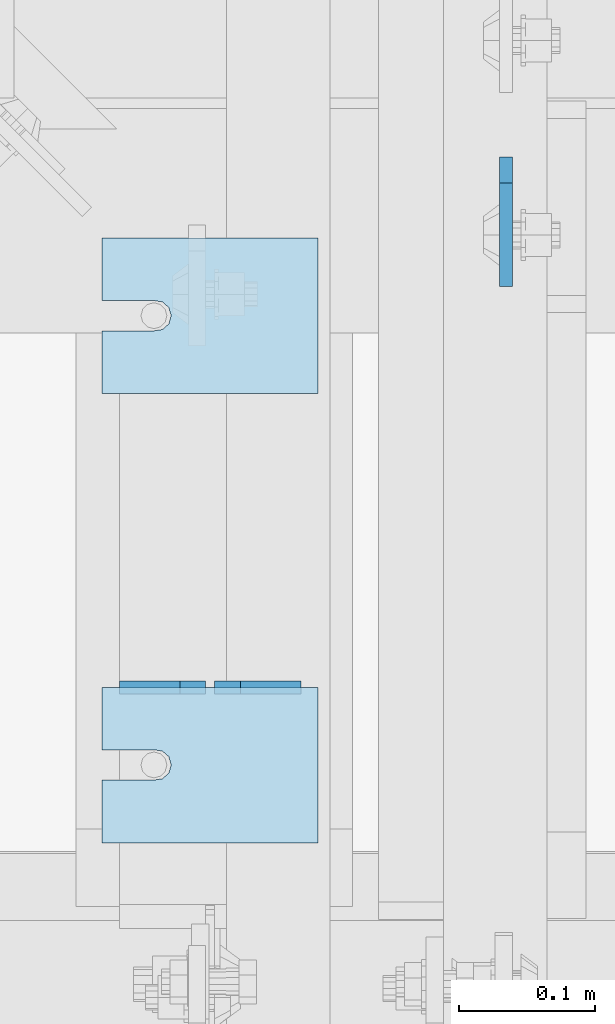
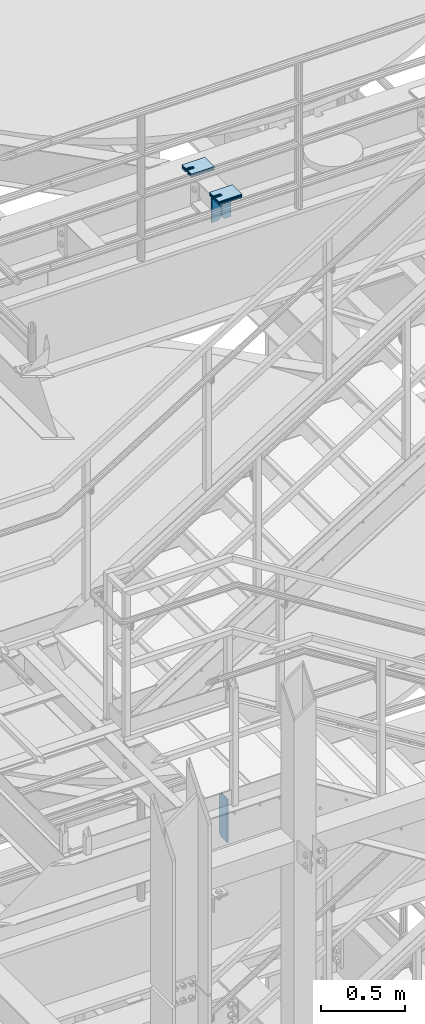
# One storey, part 1493 of 1876: 15 plates, 14 elements without a shape of their own.
"""IFC2X3 building model written with IfcOpenShell, lengths in millimetres."""

from ifc_helpers import new_model, si_unit, frame, origin_with_axes, place, context, subcontext, project, spatial, faceted_brep, material, type_object, element, aggregate, save


model = new_model("IFC2X3")

# Units and contexts
model_context = context("Model", 3, precision=1e-05, world=origin_with_axes())
body_context = subcontext(model_context, "Body", "Model", "MODEL_VIEW")
ifc_project = project(units=[si_unit("LENGTHUNIT", "METRE", prefix="MILLI"), si_unit("AREAUNIT", "SQUARE_METRE"), si_unit("VOLUMEUNIT", "CUBIC_METRE"), si_unit("MASSUNIT", "GRAM", prefix="KILO"), si_unit("TIMEUNIT", "SECOND"), si_unit("PLANEANGLEUNIT", "RADIAN"), si_unit("SOLIDANGLEUNIT", "STERADIAN"), si_unit("THERMODYNAMICTEMPERATUREUNIT", "DEGREE_CELSIUS"), si_unit("LUMINOUSINTENSITYUNIT", "LUMEN")], contexts=[model_context])

# Site, building, storey
site_placement = place(None, origin_with_axes())
site = spatial("IfcSite", under=ifc_project, at=site_placement, CompositionType="ELEMENT")
building_placement = place(site_placement, origin_with_axes())
building = spatial("IfcBuilding", under=site, at=building_placement, Name="Undefined", CompositionType="ELEMENT")
storey_placement = place(building_placement, origin_with_axes())
storey = spatial("IfcBuildingStorey", under=building, at=storey_placement, Name="Undefined", CompositionType="ELEMENT", Elevation=0.0)

# Assembly, plate
assembly_1_placement = place(storey_placement, origin_with_axes())
assembly_1 = element("IfcElementAssembly", 1, at=assembly_1_placement, inside=storey, Name="BEAM", AssemblyPlace="NOTDEFINED", PredefinedType="RIGID_FRAME")
ifc_material = material(Name="STEEL/A36")
plate_type_1 = type_object("IfcPlateType", PredefinedType="NOTDEFINED")
plate_1_placement = place(assembly_1_placement, frame((3852.86200006954, -3896.51875, 12977.8125), z_axis=(0.0, 0.0, 1.0), x_axis=(0.0, -1.0, 0.0)))
plate_1 = element("IfcPlate", 2, at=plate_1_placement, type_object=plate_type_1, material=ifc_material, Name="PLATE", context=body_context, shape_type="Brep", body=[
    faceted_brep([(0.0, -4.76249999999982, 19.0499992370605), (-1.81898940354586e-12, -4.76250000000073, 296.862499237061), (0.0, 4.76249999999982, 296.862499237061), (0.0, 4.76249999999982, 19.0499992370605), (19.0499992370605, -4.76249999999982, 315.912506103516), (19.0499992370605, 4.76249999999982, 315.912506103516), (95.25, -4.76249999999982, 315.912506103516), (95.25, 4.76249999999982, 315.912506103516), (95.25, -4.76249999999982, 0.0), (95.25, 4.76249999999982, 0.0), (19.0499992370605, -4.76249999999982, 0.0), (19.0499992370605, 4.76249999999982, 0.0)], [[[0, 1, 2, 3]], [[1, 4, 5, 2]], [[4, 6, 7, 5]], [[6, 8, 9, 7]], [[8, 10, 11, 9]], [[10, 0, 3, 11]], [[5, 7, 9, 11, 3, 2]], [[10, 8, 6, 4, 1, 0]]]),
])
aggregate(assembly_1, [plate_1])

# Assembly, plates
assembly_2_placement = place(storey_placement, origin_with_axes())
assembly_2 = element("IfcElementAssembly", 3, at=assembly_2_placement, inside=storey, Name="BEAM", AssemblyPlace="NOTDEFINED", PredefinedType="RIGID_FRAME")
plate_type_2 = type_object("IfcPlateType", PredefinedType="NOTDEFINED")
plate_2_placement = place(assembly_2_placement, frame((3702.05, -4286.24823214101, 17784.7625), z_axis=(0.0, 0.0, 1.0), x_axis=(-1.0, 0.0, 0.0)))
plate_2 = element("IfcPlate", 4, at=plate_2_placement, type_object=plate_type_2, material=ifc_material, Name="PLATE", context=body_context, shape_type="Brep", body=[
    faceted_brep([(0.0, -4.76249999999982, 0.0), (0.0, -4.76249999999982, 190.5), (0.0, 4.76249999999982, 190.5), (0.0, 4.76249999999982, 0.0), (44.4500007629395, -4.76249999999982, 190.5), (44.4500007629395, 4.76249999999982, 190.5), (63.5, -4.76249999999982, 171.450000762939), (63.5, 4.76249999999982, 171.450000762939), (63.5, -4.76249999999982, 19.0499992370605), (63.5, 4.76249999999982, 19.0499992370605), (44.4500007629395, -4.76249999999982, 0.0), (44.4500007629395, 4.76249999999982, 0.0)], [[[0, 1, 2, 3]], [[1, 4, 5, 2]], [[4, 6, 7, 5]], [[6, 8, 9, 7]], [[8, 10, 11, 9]], [[10, 0, 3, 11]], [[5, 7, 9, 11, 3, 2]], [[10, 8, 6, 4, 1, 0]]]),
])
plate_3_placement = place(assembly_2_placement, frame((3632.2, -4286.24823214101, 17784.7625), z_axis=(0.0, 0.0, 1.0), x_axis=(-1.0, 0.0, 0.0)))
plate_3 = element("IfcPlate", 5, at=plate_3_placement, type_object=plate_type_2, material=ifc_material, Name="PLATE", context=body_context, shape_type="Brep", body=[
    faceted_brep([(0.0, -4.76249999999982, 19.0499992370605), (0.0, -4.76249999999982, 171.450000762939), (0.0, 4.76249999999982, 171.450000762939), (0.0, 4.76249999999982, 19.0499992370605), (19.0499992370605, -4.76249999999982, 190.5), (19.0499992370605, 4.76249999999982, 190.5), (63.5, -4.76249999999982, 190.5), (63.5, 4.76249999999982, 190.5), (63.5, -4.76249999999982, 0.0), (63.5, 4.76249999999982, 0.0), (19.0499992370605, -4.76249999999982, 0.0), (19.0499992370605, 4.76249999999982, 0.0)], [[[0, 1, 2, 3]], [[1, 4, 5, 2]], [[4, 6, 7, 5]], [[6, 8, 9, 7]], [[8, 10, 11, 9]], [[10, 0, 3, 11]], [[5, 7, 9, 11, 3, 2]], [[10, 8, 6, 4, 1, 0]]]),
])
aggregate(assembly_2, [plate_2, plate_3])

# Assembly, plate
assembly_3_placement = place(storey_placement, origin_with_axes())
assembly_3 = element("IfcElementAssembly", 6, at=assembly_3_placement, inside=storey, Name="SHIM PLATE", AssemblyPlace="NOTDEFINED", PredefinedType="RIGID_FRAME")
plate_type_3 = type_object("IfcPlateType", PredefinedType="NOTDEFINED")
plate_4_placement = place(assembly_3_placement, frame((3714.75009928253, -4286.24823360147, 18009.3925), z_axis=(0.0, -1.0, 0.0), x_axis=(-1.0, 0.0, 0.0)))
plate_4 = element("IfcPlate", 7, at=plate_4_placement, type_object=plate_type_3, material=ifc_material, Name="SHIM PLATE", context=body_context, shape_type="Brep", body=[
    faceted_brep([(158.750372340321, -0.793499999999767, 45.9159391237008), (158.750372340321, 0.793499999999767, 45.9159391237008), (120.639297339384, 0.793499999999767, 45.9151982062995), (120.639297339384, -0.793499999999767, 45.9151982062995), (114.427892427377, 0.793499999999767, 46.8593737589063), (114.427892427377, -0.793499999999767, 46.8593737589063), (109.699635978252, 0.793499999999767, 50.9965961854132), (109.699635978252, -0.793499999999767, 50.9965961854132), (107.939290344286, 0.793499999999767, 57.0276990450948), (107.939290344286, -0.793499999999767, 57.0276990450948), (109.699637497522, 0.793499999999767, 63.0588014613368), (109.699637497522, -0.793499999999767, 63.0588014613368), (114.427894988835, 0.793499999999767, 67.1960226967731), (114.427894988835, -0.793499999999767, 67.1960226967731), (120.639300138686, 0.793499999999767, 68.140196684697), (120.639300138686, -0.793499999999767, 68.140196684697), (158.750375307166, -0.793499999999767, 68.1409376021466), (158.750375307166, 0.793499999999767, 68.1409376021466), (158.750366210938, -0.793499999999767, 5.27506927028298e-11), (9.09494701772928e-13, -0.793499999999767, 0.0), (9.09494701772928e-13, 0.793499999999767, 0.0), (158.750366210938, 0.793499999999767, 5.27506927028298e-11), (1.97695580936852e-05, -0.793499999999767, 114.305328369142), (1.97695580936852e-05, 0.793499999999767, 114.305328369142), (158.750381469715, -0.793499999999767, 114.305328369159), (158.750381469715, 0.793499999999767, 114.305328369159)], [[[0, 1, 2, 3]], [[3, 2, 4, 5]], [[5, 4, 6, 7]], [[7, 6, 8, 9]], [[9, 8, 10, 11]], [[11, 10, 12, 13]], [[13, 12, 14, 15]], [[16, 15, 14, 17]], [[18, 19, 20, 21]], [[19, 22, 23, 20]], [[22, 24, 25, 23]], [[25, 24, 16, 17]], [[12, 10, 8, 6, 4, 2, 1, 21, 20, 23, 25, 17, 14]], [[18, 21, 1, 0]], [[24, 22, 19, 18, 0, 3, 5, 7, 9, 11, 13, 15, 16]]]),
])
aggregate(assembly_3, [plate_4])

assembly_4_placement = place(storey_placement, origin_with_axes())
assembly_4 = element("IfcElementAssembly", 8, at=assembly_4_placement, inside=storey, Name="SHIM PLATE", AssemblyPlace="NOTDEFINED", PredefinedType="RIGID_FRAME")
plate_5_placement = place(assembly_4_placement, frame((3714.75009928253, -3956.04803828897, 18009.3925), z_axis=(0.0, -1.0, 0.0), x_axis=(-1.0, 0.0, 0.0)))
plate_5 = element("IfcPlate", 9, at=plate_5_placement, type_object=plate_type_3, material=ifc_material, Name="SHIM PLATE", context=body_context, shape_type="Brep", body=[
    faceted_brep([(158.750372340321, -0.793499999999767, 45.9159391237008), (158.750372340321, 0.793499999999767, 45.9159391237008), (120.639297339384, 0.793499999999767, 45.9151982062995), (120.639297339384, -0.793499999999767, 45.9151982062995), (114.427892427377, 0.793499999999767, 46.8593737589063), (114.427892427377, -0.793499999999767, 46.8593737589063), (109.699635978252, 0.793499999999767, 50.9965961854132), (109.699635978252, -0.793499999999767, 50.9965961854132), (107.939290344286, 0.793499999999767, 57.0276990450948), (107.939290344286, -0.793499999999767, 57.0276990450948), (109.699637497522, 0.793499999999767, 63.0588014613368), (109.699637497522, -0.793499999999767, 63.0588014613368), (114.427894988835, 0.793499999999767, 67.1960226967731), (114.427894988835, -0.793499999999767, 67.1960226967731), (120.639300138686, 0.793499999999767, 68.140196684697), (120.639300138686, -0.793499999999767, 68.140196684697), (158.750375307166, -0.793499999999767, 68.1409376021466), (158.750375307166, 0.793499999999767, 68.1409376021466), (158.750366210938, -0.793499999999767, 5.27506927028298e-11), (9.09494701772928e-13, -0.793499999999767, 0.0), (9.09494701772928e-13, 0.793499999999767, 0.0), (158.750366210938, 0.793499999999767, 5.27506927028298e-11), (1.97695580936852e-05, -0.793499999999767, 114.305328369142), (1.97695580936852e-05, 0.793499999999767, 114.305328369142), (158.750381469715, -0.793499999999767, 114.305328369159), (158.750381469715, 0.793499999999767, 114.305328369159)], [[[0, 1, 2, 3]], [[3, 2, 4, 5]], [[5, 4, 6, 7]], [[7, 6, 8, 9]], [[9, 8, 10, 11]], [[11, 10, 12, 13]], [[13, 12, 14, 15]], [[16, 15, 14, 17]], [[18, 19, 20, 21]], [[19, 22, 23, 20]], [[22, 24, 25, 23]], [[25, 24, 16, 17]], [[12, 10, 8, 6, 4, 2, 1, 21, 20, 23, 25, 17, 14]], [[18, 21, 1, 0]], [[24, 22, 19, 18, 0, 3, 5, 7, 9, 11, 13, 15, 16]]]),
])
aggregate(assembly_4, [plate_5])

assembly_5_placement = place(storey_placement, origin_with_axes())
assembly_5 = element("IfcElementAssembly", 10, at=assembly_5_placement, inside=storey, Name="SHIM PLATE", AssemblyPlace="NOTDEFINED", PredefinedType="RIGID_FRAME")
plate_type_4 = type_object("IfcPlateType", PredefinedType="NOTDEFINED")
plate_6_placement = place(assembly_5_placement, frame((3714.75009928252, -4286.24823360146, 18007.0115), z_axis=(0.0, -1.0, 0.0), x_axis=(-1.0, 0.0, 0.0)))
plate_6 = element("IfcPlate", 11, at=plate_6_placement, type_object=plate_type_4, material=ifc_material, Name="SHIM PLATE", context=body_context, shape_type="Brep", body=[
    faceted_brep([(158.750372340321, -1.58750000000146, 45.9159391237008), (158.750372340321, 1.58750000000146, 45.9159391237008), (120.639297339383, 1.58750000000146, 45.9151982062995), (120.639297339383, -1.58750000000146, 45.9151982062995), (114.427892427376, 1.58750000000146, 46.8593737589063), (114.427892427376, -1.58750000000146, 46.8593737589063), (109.699635978252, 1.58750000000146, 50.9965961854132), (109.699635978252, -1.58750000000146, 50.9965961854132), (107.939290344285, 1.58750000000146, 57.0276990450948), (107.939290344285, -1.58750000000146, 57.0276990450948), (109.699637497522, 1.58750000000146, 63.0588014613368), (109.699637497522, -1.58750000000146, 63.0588014613368), (114.427894988834, 1.58750000000146, 67.1960226967731), (114.427894988834, -1.58750000000146, 67.1960226967731), (120.639300138685, 1.58750000000146, 68.140196684697), (120.639300138685, -1.58750000000146, 68.140196684697), (158.750375307166, -1.58750000000146, 68.1409376021466), (158.750375307166, 1.58750000000146, 68.1409376021466), (158.750366210938, -1.58750000000146, 5.27506927028298e-11), (9.09494701772928e-13, -1.58750000000146, 4.54747350886464e-13), (9.09494701772928e-13, 1.58750000000146, 4.54747350886464e-13), (158.750366210938, 1.58750000000146, 5.27506927028298e-11), (1.97695599126746e-05, -1.58750000000146, 114.305328369142), (1.97695599126746e-05, 1.58750000000146, 114.305328369142), (158.750381469715, -1.58750000000146, 114.305328369159), (158.750381469715, 1.58750000000146, 114.305328369159)], [[[0, 1, 2, 3]], [[3, 2, 4, 5]], [[5, 4, 6, 7]], [[7, 6, 8, 9]], [[9, 8, 10, 11]], [[11, 10, 12, 13]], [[13, 12, 14, 15]], [[16, 15, 14, 17]], [[18, 19, 20, 21]], [[19, 22, 23, 20]], [[22, 24, 25, 23]], [[25, 24, 16, 17]], [[12, 10, 8, 6, 4, 2, 1, 21, 20, 23, 25, 17, 14]], [[18, 21, 1, 0]], [[24, 22, 19, 18, 0, 3, 5, 7, 9, 11, 13, 15, 16]]]),
])
aggregate(assembly_5, [plate_6])

assembly_6_placement = place(storey_placement, origin_with_axes())
assembly_6 = element("IfcElementAssembly", 12, at=assembly_6_placement, inside=storey, Name="SHIM PLATE", AssemblyPlace="NOTDEFINED", PredefinedType="RIGID_FRAME")
plate_7_placement = place(assembly_6_placement, frame((3714.75009928253, -4286.24823360147, 18003.8365), z_axis=(0.0, -1.0, 0.0), x_axis=(-1.0, 0.0, 0.0)))
plate_7 = element("IfcPlate", 13, at=plate_7_placement, type_object=plate_type_4, material=ifc_material, Name="SHIM PLATE", context=body_context, shape_type="Brep", body=[
    faceted_brep([(158.750372340321, -1.58750000000146, 45.9159391237008), (158.750372340321, 1.58750000000146, 45.9159391237008), (120.639297339383, 1.58750000000146, 45.9151982062995), (120.639297339383, -1.58750000000146, 45.9151982062995), (114.427892427376, 1.58750000000146, 46.8593737589063), (114.427892427376, -1.58750000000146, 46.8593737589063), (109.699635978252, 1.58750000000146, 50.9965961854132), (109.699635978252, -1.58750000000146, 50.9965961854132), (107.939290344285, 1.58750000000146, 57.0276990450948), (107.939290344285, -1.58750000000146, 57.0276990450948), (109.699637497522, 1.58750000000146, 63.0588014613368), (109.699637497522, -1.58750000000146, 63.0588014613368), (114.427894988834, 1.58750000000146, 67.1960226967731), (114.427894988834, -1.58750000000146, 67.1960226967731), (120.639300138685, 1.58750000000146, 68.140196684697), (120.639300138685, -1.58750000000146, 68.140196684697), (158.750375307166, -1.58750000000146, 68.1409376021466), (158.750375307166, 1.58750000000146, 68.1409376021466), (158.750366210938, -1.58750000000146, 5.27506927028298e-11), (9.09494701772928e-13, -1.58750000000146, 4.54747350886464e-13), (9.09494701772928e-13, 1.58750000000146, 4.54747350886464e-13), (158.750366210938, 1.58750000000146, 5.27506927028298e-11), (1.97695599126746e-05, -1.58750000000146, 114.305328369142), (1.97695599126746e-05, 1.58750000000146, 114.305328369142), (158.750381469715, -1.58750000000146, 114.305328369159), (158.750381469715, 1.58750000000146, 114.305328369159)], [[[0, 1, 2, 3]], [[3, 2, 4, 5]], [[5, 4, 6, 7]], [[7, 6, 8, 9]], [[9, 8, 10, 11]], [[11, 10, 12, 13]], [[13, 12, 14, 15]], [[16, 15, 14, 17]], [[18, 19, 20, 21]], [[19, 22, 23, 20]], [[22, 24, 25, 23]], [[25, 24, 16, 17]], [[12, 10, 8, 6, 4, 2, 1, 21, 20, 23, 25, 17, 14]], [[18, 21, 1, 0]], [[24, 22, 19, 18, 0, 3, 5, 7, 9, 11, 13, 15, 16]]]),
])
aggregate(assembly_6, [plate_7])

assembly_7_placement = place(storey_placement, origin_with_axes())
assembly_7 = element("IfcElementAssembly", 14, at=assembly_7_placement, inside=storey, Name="SHIM PLATE", AssemblyPlace="NOTDEFINED", PredefinedType="RIGID_FRAME")
plate_8_placement = place(assembly_7_placement, frame((3714.75009928252, -3956.04803828897, 18007.0115), z_axis=(0.0, -1.0, 0.0), x_axis=(-1.0, 0.0, 0.0)))
plate_8 = element("IfcPlate", 15, at=plate_8_placement, type_object=plate_type_4, material=ifc_material, Name="SHIM PLATE", context=body_context, shape_type="Brep", body=[
    faceted_brep([(158.750372340321, -1.58750000000146, 45.9159391237008), (158.750372340321, 1.58750000000146, 45.9159391237008), (120.639297339383, 1.58750000000146, 45.9151982062995), (120.639297339383, -1.58750000000146, 45.9151982062995), (114.427892427376, 1.58750000000146, 46.8593737589063), (114.427892427376, -1.58750000000146, 46.8593737589063), (109.699635978252, 1.58750000000146, 50.9965961854132), (109.699635978252, -1.58750000000146, 50.9965961854132), (107.939290344285, 1.58750000000146, 57.0276990450948), (107.939290344285, -1.58750000000146, 57.0276990450948), (109.699637497522, 1.58750000000146, 63.0588014613368), (109.699637497522, -1.58750000000146, 63.0588014613368), (114.427894988834, 1.58750000000146, 67.1960226967731), (114.427894988834, -1.58750000000146, 67.1960226967731), (120.639300138685, 1.58750000000146, 68.140196684697), (120.639300138685, -1.58750000000146, 68.140196684697), (158.750375307166, -1.58750000000146, 68.1409376021466), (158.750375307166, 1.58750000000146, 68.1409376021466), (158.750366210938, -1.58750000000146, 5.27506927028298e-11), (9.09494701772928e-13, -1.58750000000146, 4.54747350886464e-13), (9.09494701772928e-13, 1.58750000000146, 4.54747350886464e-13), (158.750366210938, 1.58750000000146, 5.27506927028298e-11), (1.97695599126746e-05, -1.58750000000146, 114.305328369142), (1.97695599126746e-05, 1.58750000000146, 114.305328369142), (158.750381469715, -1.58750000000146, 114.305328369159), (158.750381469715, 1.58750000000146, 114.305328369159)], [[[0, 1, 2, 3]], [[3, 2, 4, 5]], [[5, 4, 6, 7]], [[7, 6, 8, 9]], [[9, 8, 10, 11]], [[11, 10, 12, 13]], [[13, 12, 14, 15]], [[16, 15, 14, 17]], [[18, 19, 20, 21]], [[19, 22, 23, 20]], [[22, 24, 25, 23]], [[25, 24, 16, 17]], [[12, 10, 8, 6, 4, 2, 1, 21, 20, 23, 25, 17, 14]], [[18, 21, 1, 0]], [[24, 22, 19, 18, 0, 3, 5, 7, 9, 11, 13, 15, 16]]]),
])
aggregate(assembly_7, [plate_8])

assembly_8_placement = place(storey_placement, origin_with_axes())
assembly_8 = element("IfcElementAssembly", 16, at=assembly_8_placement, inside=storey, Name="SHIM PLATE", AssemblyPlace="NOTDEFINED", PredefinedType="RIGID_FRAME")
plate_9_placement = place(assembly_8_placement, frame((3714.75009928253, -3956.04803828897, 18003.8365), z_axis=(0.0, -1.0, 0.0), x_axis=(-1.0, 0.0, 0.0)))
plate_9 = element("IfcPlate", 17, at=plate_9_placement, type_object=plate_type_4, material=ifc_material, Name="SHIM PLATE", context=body_context, shape_type="Brep", body=[
    faceted_brep([(158.750372340321, -1.58750000000146, 45.9159391237008), (158.750372340321, 1.58750000000146, 45.9159391237008), (120.639297339383, 1.58750000000146, 45.9151982062995), (120.639297339383, -1.58750000000146, 45.9151982062995), (114.427892427376, 1.58750000000146, 46.8593737589063), (114.427892427376, -1.58750000000146, 46.8593737589063), (109.699635978252, 1.58750000000146, 50.9965961854132), (109.699635978252, -1.58750000000146, 50.9965961854132), (107.939290344285, 1.58750000000146, 57.0276990450948), (107.939290344285, -1.58750000000146, 57.0276990450948), (109.699637497522, 1.58750000000146, 63.0588014613368), (109.699637497522, -1.58750000000146, 63.0588014613368), (114.427894988834, 1.58750000000146, 67.1960226967731), (114.427894988834, -1.58750000000146, 67.1960226967731), (120.639300138685, 1.58750000000146, 68.140196684697), (120.639300138685, -1.58750000000146, 68.140196684697), (158.750375307166, -1.58750000000146, 68.1409376021466), (158.750375307166, 1.58750000000146, 68.1409376021466), (158.750366210938, -1.58750000000146, 5.27506927028298e-11), (9.09494701772928e-13, -1.58750000000146, 4.54747350886464e-13), (9.09494701772928e-13, 1.58750000000146, 4.54747350886464e-13), (158.750366210938, 1.58750000000146, 5.27506927028298e-11), (1.97695599126746e-05, -1.58750000000146, 114.305328369142), (1.97695599126746e-05, 1.58750000000146, 114.305328369142), (158.750381469715, -1.58750000000146, 114.305328369159), (158.750381469715, 1.58750000000146, 114.305328369159)], [[[0, 1, 2, 3]], [[3, 2, 4, 5]], [[5, 4, 6, 7]], [[7, 6, 8, 9]], [[9, 8, 10, 11]], [[11, 10, 12, 13]], [[13, 12, 14, 15]], [[16, 15, 14, 17]], [[18, 19, 20, 21]], [[19, 22, 23, 20]], [[22, 24, 25, 23]], [[25, 24, 16, 17]], [[12, 10, 8, 6, 4, 2, 1, 21, 20, 23, 25, 17, 14]], [[18, 21, 1, 0]], [[24, 22, 19, 18, 0, 3, 5, 7, 9, 11, 13, 15, 16]]]),
])
aggregate(assembly_8, [plate_9])

assembly_9_placement = place(storey_placement, origin_with_axes())
assembly_9 = element("IfcElementAssembly", 18, at=assembly_9_placement, inside=storey, Name="SHIM PLATE", AssemblyPlace="NOTDEFINED", PredefinedType="RIGID_FRAME")
plate_type_5 = type_object("IfcPlateType", PredefinedType="NOTDEFINED")
plate_10_placement = place(assembly_9_placement, frame((3714.75009928253, -4286.24823360147, 17999.868), z_axis=(0.0, -1.0, 0.0), x_axis=(-1.0, 0.0, 0.0)))
plate_10 = element("IfcPlate", 19, at=plate_10_placement, type_object=plate_type_5, material=ifc_material, Name="SHIM PLATE", context=body_context, shape_type="Brep", body=[
    faceted_brep([(158.750372340321, -2.38100000000122, 45.9159391237008), (158.750372340321, 2.38100000000122, 45.9159391237008), (120.639297339384, 2.38100000000122, 45.9151982062995), (120.639297339384, -2.38100000000122, 45.9151982062995), (114.427892427377, 2.38100000000122, 46.8593737589063), (114.427892427377, -2.38100000000122, 46.8593737589063), (109.699635978252, 2.38100000000122, 50.9965961854132), (109.699635978252, -2.38100000000122, 50.9965961854132), (107.939290344286, 2.38100000000122, 57.0276990450948), (107.939290344286, -2.38100000000122, 57.0276990450948), (109.699637497522, 2.38100000000122, 63.0588014613368), (109.699637497522, -2.38100000000122, 63.0588014613368), (114.427894988835, 2.38100000000122, 67.1960226967731), (114.427894988835, -2.38100000000122, 67.1960226967731), (120.639300138686, 2.38100000000122, 68.140196684697), (120.639300138686, -2.38100000000122, 68.140196684697), (158.750375307166, -2.38100000000122, 68.1409376021466), (158.750375307166, 2.38100000000122, 68.1409376021466), (158.750366210938, -2.38100000000122, 5.27506927028298e-11), (0.0, -2.38100000000122, 4.54747350886464e-13), (0.0, 2.38100000000122, 4.54747350886464e-13), (158.750366210938, 2.38100000000122, 5.27506927028298e-11), (1.9769561731664e-05, -2.38100000000122, 114.305328369142), (1.9769561731664e-05, 2.38100000000122, 114.305328369142), (158.750381469715, -2.38100000000122, 114.305328369159), (158.750381469715, 2.38100000000122, 114.305328369159)], [[[0, 1, 2, 3]], [[3, 2, 4, 5]], [[5, 4, 6, 7]], [[7, 6, 8, 9]], [[9, 8, 10, 11]], [[11, 10, 12, 13]], [[13, 12, 14, 15]], [[16, 15, 14, 17]], [[18, 19, 20, 21]], [[19, 22, 23, 20]], [[22, 24, 25, 23]], [[25, 24, 16, 17]], [[12, 10, 8, 6, 4, 2, 1, 21, 20, 23, 25, 17, 14]], [[18, 21, 1, 0]], [[24, 22, 19, 18, 0, 3, 5, 7, 9, 11, 13, 15, 16]]]),
])
aggregate(assembly_9, [plate_10])

assembly_10_placement = place(storey_placement, origin_with_axes())
assembly_10 = element("IfcElementAssembly", 20, at=assembly_10_placement, inside=storey, Name="SHIM PLATE", AssemblyPlace="NOTDEFINED", PredefinedType="RIGID_FRAME")
plate_11_placement = place(assembly_10_placement, frame((3714.75009928253, -4286.24823360146, 17995.106), z_axis=(0.0, -1.0, 0.0), x_axis=(-1.0, 0.0, 0.0)))
plate_11 = element("IfcPlate", 21, at=plate_11_placement, type_object=plate_type_5, material=ifc_material, Name="SHIM PLATE", context=body_context, shape_type="Brep", body=[
    faceted_brep([(158.750372340321, -2.38100000000122, 45.9159391237008), (158.750372340321, 2.38100000000122, 45.9159391237008), (120.639297339384, 2.38100000000122, 45.9151982062995), (120.639297339384, -2.38100000000122, 45.9151982062995), (114.427892427377, 2.38100000000122, 46.8593737589063), (114.427892427377, -2.38100000000122, 46.8593737589063), (109.699635978252, 2.38100000000122, 50.9965961854132), (109.699635978252, -2.38100000000122, 50.9965961854132), (107.939290344286, 2.38100000000122, 57.0276990450948), (107.939290344286, -2.38100000000122, 57.0276990450948), (109.699637497522, 2.38100000000122, 63.0588014613368), (109.699637497522, -2.38100000000122, 63.0588014613368), (114.427894988835, 2.38100000000122, 67.1960226967731), (114.427894988835, -2.38100000000122, 67.1960226967731), (120.639300138686, 2.38100000000122, 68.140196684697), (120.639300138686, -2.38100000000122, 68.140196684697), (158.750375307166, -2.38100000000122, 68.1409376021466), (158.750375307166, 2.38100000000122, 68.1409376021466), (158.750366210938, -2.38100000000122, 5.27506927028298e-11), (0.0, -2.38100000000122, 4.54747350886464e-13), (0.0, 2.38100000000122, 4.54747350886464e-13), (158.750366210938, 2.38100000000122, 5.27506927028298e-11), (1.9769561731664e-05, -2.38100000000122, 114.305328369142), (1.9769561731664e-05, 2.38100000000122, 114.305328369142), (158.750381469715, -2.38100000000122, 114.305328369159), (158.750381469715, 2.38100000000122, 114.305328369159)], [[[0, 1, 2, 3]], [[3, 2, 4, 5]], [[5, 4, 6, 7]], [[7, 6, 8, 9]], [[9, 8, 10, 11]], [[11, 10, 12, 13]], [[13, 12, 14, 15]], [[16, 15, 14, 17]], [[18, 19, 20, 21]], [[19, 22, 23, 20]], [[22, 24, 25, 23]], [[25, 24, 16, 17]], [[12, 10, 8, 6, 4, 2, 1, 21, 20, 23, 25, 17, 14]], [[18, 21, 1, 0]], [[24, 22, 19, 18, 0, 3, 5, 7, 9, 11, 13, 15, 16]]]),
])
aggregate(assembly_10, [plate_11])

assembly_11_placement = place(storey_placement, origin_with_axes())
assembly_11 = element("IfcElementAssembly", 22, at=assembly_11_placement, inside=storey, Name="SHIM PLATE", AssemblyPlace="NOTDEFINED", PredefinedType="RIGID_FRAME")
plate_12_placement = place(assembly_11_placement, frame((3714.75009928253, -3956.04803828897, 17999.868), z_axis=(0.0, -1.0, 0.0), x_axis=(-1.0, 0.0, 0.0)))
plate_12 = element("IfcPlate", 23, at=plate_12_placement, type_object=plate_type_5, material=ifc_material, Name="SHIM PLATE", context=body_context, shape_type="Brep", body=[
    faceted_brep([(158.750372340321, -2.38100000000122, 45.9159391237008), (158.750372340321, 2.38100000000122, 45.9159391237008), (120.639297339384, 2.38100000000122, 45.9151982062995), (120.639297339384, -2.38100000000122, 45.9151982062995), (114.427892427377, 2.38100000000122, 46.8593737589063), (114.427892427377, -2.38100000000122, 46.8593737589063), (109.699635978252, 2.38100000000122, 50.9965961854132), (109.699635978252, -2.38100000000122, 50.9965961854132), (107.939290344286, 2.38100000000122, 57.0276990450948), (107.939290344286, -2.38100000000122, 57.0276990450948), (109.699637497522, 2.38100000000122, 63.0588014613368), (109.699637497522, -2.38100000000122, 63.0588014613368), (114.427894988835, 2.38100000000122, 67.1960226967731), (114.427894988835, -2.38100000000122, 67.1960226967731), (120.639300138686, 2.38100000000122, 68.140196684697), (120.639300138686, -2.38100000000122, 68.140196684697), (158.750375307166, -2.38100000000122, 68.1409376021466), (158.750375307166, 2.38100000000122, 68.1409376021466), (158.750366210938, -2.38100000000122, 5.27506927028298e-11), (0.0, -2.38100000000122, 4.54747350886464e-13), (0.0, 2.38100000000122, 4.54747350886464e-13), (158.750366210938, 2.38100000000122, 5.27506927028298e-11), (1.9769561731664e-05, -2.38100000000122, 114.305328369142), (1.9769561731664e-05, 2.38100000000122, 114.305328369142), (158.750381469715, -2.38100000000122, 114.305328369159), (158.750381469715, 2.38100000000122, 114.305328369159)], [[[0, 1, 2, 3]], [[3, 2, 4, 5]], [[5, 4, 6, 7]], [[7, 6, 8, 9]], [[9, 8, 10, 11]], [[11, 10, 12, 13]], [[13, 12, 14, 15]], [[16, 15, 14, 17]], [[18, 19, 20, 21]], [[19, 22, 23, 20]], [[22, 24, 25, 23]], [[25, 24, 16, 17]], [[12, 10, 8, 6, 4, 2, 1, 21, 20, 23, 25, 17, 14]], [[18, 21, 1, 0]], [[24, 22, 19, 18, 0, 3, 5, 7, 9, 11, 13, 15, 16]]]),
])
aggregate(assembly_11, [plate_12])

assembly_12_placement = place(storey_placement, origin_with_axes())
assembly_12 = element("IfcElementAssembly", 24, at=assembly_12_placement, inside=storey, Name="SHIM PLATE", AssemblyPlace="NOTDEFINED", PredefinedType="RIGID_FRAME")
plate_13_placement = place(assembly_12_placement, frame((3714.75009928253, -3956.04803828897, 17995.106), z_axis=(0.0, -1.0, 0.0), x_axis=(-1.0, 0.0, 0.0)))
plate_13 = element("IfcPlate", 25, at=plate_13_placement, type_object=plate_type_5, material=ifc_material, Name="SHIM PLATE", context=body_context, shape_type="Brep", body=[
    faceted_brep([(158.750372340321, -2.38100000000122, 45.9159391237008), (158.750372340321, 2.38100000000122, 45.9159391237008), (120.639297339384, 2.38100000000122, 45.9151982062995), (120.639297339384, -2.38100000000122, 45.9151982062995), (114.427892427377, 2.38100000000122, 46.8593737589063), (114.427892427377, -2.38100000000122, 46.8593737589063), (109.699635978252, 2.38100000000122, 50.9965961854132), (109.699635978252, -2.38100000000122, 50.9965961854132), (107.939290344286, 2.38100000000122, 57.0276990450948), (107.939290344286, -2.38100000000122, 57.0276990450948), (109.699637497522, 2.38100000000122, 63.0588014613368), (109.699637497522, -2.38100000000122, 63.0588014613368), (114.427894988835, 2.38100000000122, 67.1960226967731), (114.427894988835, -2.38100000000122, 67.1960226967731), (120.639300138686, 2.38100000000122, 68.140196684697), (120.639300138686, -2.38100000000122, 68.140196684697), (158.750375307166, -2.38100000000122, 68.1409376021466), (158.750375307166, 2.38100000000122, 68.1409376021466), (158.750366210938, -2.38100000000122, 5.27506927028298e-11), (0.0, -2.38100000000122, 4.54747350886464e-13), (0.0, 2.38100000000122, 4.54747350886464e-13), (158.750366210938, 2.38100000000122, 5.27506927028298e-11), (1.9769561731664e-05, -2.38100000000122, 114.305328369142), (1.9769561731664e-05, 2.38100000000122, 114.305328369142), (158.750381469715, -2.38100000000122, 114.305328369159), (158.750381469715, 2.38100000000122, 114.305328369159)], [[[0, 1, 2, 3]], [[3, 2, 4, 5]], [[5, 4, 6, 7]], [[7, 6, 8, 9]], [[9, 8, 10, 11]], [[11, 10, 12, 13]], [[13, 12, 14, 15]], [[16, 15, 14, 17]], [[18, 19, 20, 21]], [[19, 22, 23, 20]], [[22, 24, 25, 23]], [[25, 24, 16, 17]], [[12, 10, 8, 6, 4, 2, 1, 21, 20, 23, 25, 17, 14]], [[18, 21, 1, 0]], [[24, 22, 19, 18, 0, 3, 5, 7, 9, 11, 13, 15, 16]]]),
])
aggregate(assembly_12, [plate_13])

assembly_13_placement = place(storey_placement, origin_with_axes())
assembly_13 = element("IfcElementAssembly", 26, at=assembly_13_placement, inside=storey, Name="SHIM PLATE", AssemblyPlace="NOTDEFINED", PredefinedType="RIGID_FRAME")
plate_type_6 = type_object("IfcPlateType", PredefinedType="NOTDEFINED")
plate_14_placement = place(assembly_13_placement, frame((3714.75009928253, -4286.24823360146, 17987.9625), z_axis=(0.0, -1.0, 0.0), x_axis=(-1.0, 0.0, 0.0)))
plate_14 = element("IfcPlate", 27, at=plate_14_placement, type_object=plate_type_6, material=ifc_material, Name="SHIM PLATE", context=body_context, shape_type="Brep", body=[
    faceted_brep([(158.750372340321, -4.76250000000073, 45.9159391237008), (158.750372340321, 4.76250000000073, 45.9159391237008), (120.639297339384, 4.76250000000073, 45.9151982062995), (120.639297339384, -4.76250000000073, 45.9151982062995), (114.427892427377, 4.76250000000073, 46.8593737589063), (114.427892427377, -4.76250000000073, 46.8593737589063), (109.699635978252, 4.76250000000073, 50.9965961854132), (109.699635978252, -4.76250000000073, 50.9965961854132), (107.939290344286, 4.76250000000073, 57.0276990450948), (107.939290344286, -4.76250000000073, 57.0276990450948), (109.699637497522, 4.76250000000073, 63.0588014613368), (109.699637497522, -4.76250000000073, 63.0588014613368), (114.427894988835, 4.76250000000073, 67.1960226967731), (114.427894988835, -4.76250000000073, 67.1960226967731), (120.639300138686, 4.76250000000073, 68.140196684697), (120.639300138686, -4.76250000000073, 68.140196684697), (158.750375307166, -4.76250000000073, 68.1409376021466), (158.750375307166, 4.76250000000073, 68.1409376021466), (158.750366210938, -4.76250000000073, 5.27506927028298e-11), (0.0, -4.76249999999982, 0.0), (0.0, 4.76249999999982, 0.0), (158.750366210938, 4.76250000000073, 5.27506927028298e-11), (1.97695635506534e-05, -4.76250000000073, 114.305328369142), (1.97695635506534e-05, 4.76250000000073, 114.305328369142), (158.750381469715, -4.76250000000073, 114.305328369159), (158.750381469715, 4.76250000000073, 114.305328369159)], [[[0, 1, 2, 3]], [[3, 2, 4, 5]], [[5, 4, 6, 7]], [[7, 6, 8, 9]], [[9, 8, 10, 11]], [[11, 10, 12, 13]], [[13, 12, 14, 15]], [[16, 15, 14, 17]], [[18, 19, 20, 21]], [[19, 22, 23, 20]], [[22, 24, 25, 23]], [[25, 24, 16, 17]], [[12, 10, 8, 6, 4, 2, 1, 21, 20, 23, 25, 17, 14]], [[18, 21, 1, 0]], [[24, 22, 19, 18, 0, 3, 5, 7, 9, 11, 13, 15, 16]]]),
])
aggregate(assembly_13, [plate_14])

assembly_14_placement = place(storey_placement, origin_with_axes())
assembly_14 = element("IfcElementAssembly", 28, at=assembly_14_placement, inside=storey, Name="SHIM PLATE", AssemblyPlace="NOTDEFINED", PredefinedType="RIGID_FRAME")
plate_15_placement = place(assembly_14_placement, frame((3714.75009928253, -3956.04803828897, 17987.9625), z_axis=(0.0, -1.0, 0.0), x_axis=(-1.0, 0.0, 0.0)))
plate_15 = element("IfcPlate", 29, at=plate_15_placement, type_object=plate_type_6, material=ifc_material, Name="SHIM PLATE", context=body_context, shape_type="Brep", body=[
    faceted_brep([(158.750372340321, -4.76250000000073, 45.9159391237008), (158.750372340321, 4.76250000000073, 45.9159391237008), (120.639297339384, 4.76250000000073, 45.9151982062995), (120.639297339384, -4.76250000000073, 45.9151982062995), (114.427892427377, 4.76250000000073, 46.8593737589063), (114.427892427377, -4.76250000000073, 46.8593737589063), (109.699635978252, 4.76250000000073, 50.9965961854132), (109.699635978252, -4.76250000000073, 50.9965961854132), (107.939290344286, 4.76250000000073, 57.0276990450948), (107.939290344286, -4.76250000000073, 57.0276990450948), (109.699637497522, 4.76250000000073, 63.0588014613368), (109.699637497522, -4.76250000000073, 63.0588014613368), (114.427894988835, 4.76250000000073, 67.1960226967731), (114.427894988835, -4.76250000000073, 67.1960226967731), (120.639300138686, 4.76250000000073, 68.140196684697), (120.639300138686, -4.76250000000073, 68.140196684697), (158.750375307166, -4.76250000000073, 68.1409376021466), (158.750375307166, 4.76250000000073, 68.1409376021466), (158.750366210938, -4.76250000000073, 5.27506927028298e-11), (0.0, -4.76249999999982, 0.0), (0.0, 4.76249999999982, 0.0), (158.750366210938, 4.76250000000073, 5.27506927028298e-11), (1.97695635506534e-05, -4.76250000000073, 114.305328369142), (1.97695635506534e-05, 4.76250000000073, 114.305328369142), (158.750381469715, -4.76250000000073, 114.305328369159), (158.750381469715, 4.76250000000073, 114.305328369159)], [[[0, 1, 2, 3]], [[3, 2, 4, 5]], [[5, 4, 6, 7]], [[7, 6, 8, 9]], [[9, 8, 10, 11]], [[11, 10, 12, 13]], [[13, 12, 14, 15]], [[16, 15, 14, 17]], [[18, 19, 20, 21]], [[19, 22, 23, 20]], [[22, 24, 25, 23]], [[25, 24, 16, 17]], [[12, 10, 8, 6, 4, 2, 1, 21, 20, 23, 25, 17, 14]], [[18, 21, 1, 0]], [[24, 22, 19, 18, 0, 3, 5, 7, 9, 11, 13, 15, 16]]]),
])
aggregate(assembly_14, [plate_15])

save(model, "model.ifc")
